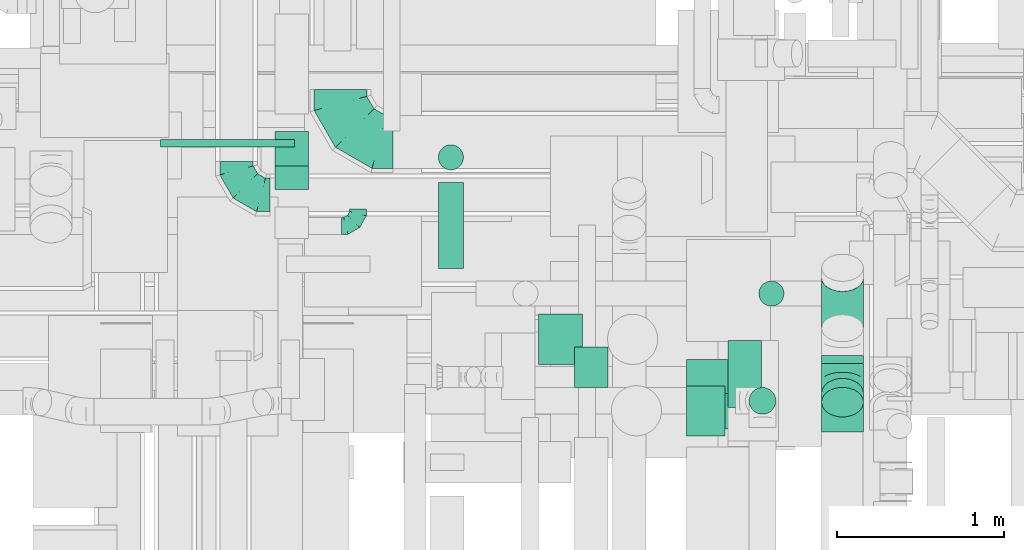
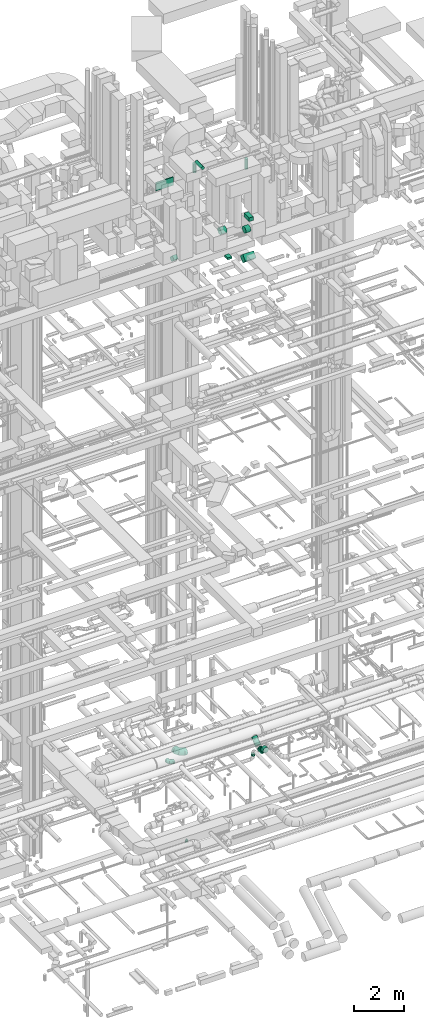
# One storey, part 185 of 337: 14 flow segments, 5 flow fittings.
"""IFC2X3 building model written with IfcOpenShell, lengths in millimetres."""

from ifc_helpers import new_model, entity, si_unit, converted_unit, derived_unit, direction, frame, frame_2d, origin, origin_2d_with_axis, place, context, subcontext, project, spatial, rectangle, circle, extrude, faceted_brep, source, transform, mapped, material, type_object, type_shapes, element, save


model = new_model("IFC2X3")

# Units and contexts
model_context = context("Model", 3, precision=0.01, world=origin(), true_north=direction((6.12303176911189e-17, 1.0)))
body_context = subcontext(model_context, "Body", "Model", "MODEL_VIEW")
ifc_project = project(units=[si_unit("LENGTHUNIT", "METRE", prefix="MILLI"), si_unit("AREAUNIT", "SQUARE_METRE"), si_unit("VOLUMEUNIT", "CUBIC_METRE"), converted_unit("PLANEANGLEUNIT", "DEGREE", entity("IfcRatioMeasure", 0.0174532925199433), si_unit("PLANEANGLEUNIT", "RADIAN"), dimensions=[0, 0, 0, 0, 0, 0, 0]), si_unit("MASSUNIT", "GRAM", prefix="KILO"), derived_unit("MASSDENSITYUNIT", [(si_unit("MASSUNIT", "GRAM", prefix="KILO"), 1), (si_unit("LENGTHUNIT", "METRE"), -3)]), derived_unit("MOMENTOFINERTIAUNIT", [(si_unit("LENGTHUNIT", "METRE"), 4)]), si_unit("TIMEUNIT", "SECOND"), si_unit("FREQUENCYUNIT", "HERTZ"), si_unit("THERMODYNAMICTEMPERATUREUNIT", "DEGREE_CELSIUS"), derived_unit("THERMALTRANSMITTANCEUNIT", [(si_unit("MASSUNIT", "GRAM", prefix="KILO"), 1), (si_unit("THERMODYNAMICTEMPERATUREUNIT", "KELVIN"), -1), (si_unit("TIMEUNIT", "SECOND"), -3)]), derived_unit("VOLUMETRICFLOWRATEUNIT", [(si_unit("LENGTHUNIT", "METRE"), 3), (si_unit("TIMEUNIT", "SECOND"), -1)]), derived_unit("MASSFLOWRATEUNIT", [(si_unit("MASSUNIT", "GRAM", prefix="KILO"), 1), (si_unit("TIMEUNIT", "SECOND"), -1)]), derived_unit("ROTATIONALFREQUENCYUNIT", [(si_unit("TIMEUNIT", "SECOND"), -1)]), si_unit("ELECTRICCURRENTUNIT", "AMPERE"), si_unit("ELECTRICVOLTAGEUNIT", "VOLT"), si_unit("POWERUNIT", "WATT"), si_unit("FORCEUNIT", "NEWTON", prefix="KILO"), si_unit("ILLUMINANCEUNIT", "LUX"), si_unit("LUMINOUSFLUXUNIT", "LUMEN"), si_unit("LUMINOUSINTENSITYUNIT", "CANDELA"), derived_unit("USERDEFINED", [(si_unit("MASSUNIT", "GRAM", prefix="KILO"), -1), (si_unit("LENGTHUNIT", "METRE"), -2), (si_unit("TIMEUNIT", "SECOND"), 3), (si_unit("LUMINOUSFLUXUNIT", "LUMEN"), 1)]), derived_unit("LINEARVELOCITYUNIT", [(si_unit("LENGTHUNIT", "METRE"), 1), (si_unit("TIMEUNIT", "SECOND"), -1)]), si_unit("PRESSUREUNIT", "PASCAL"), derived_unit("USERDEFINED", [(si_unit("LENGTHUNIT", "METRE"), -2), (si_unit("MASSUNIT", "GRAM", prefix="KILO"), 1), (si_unit("TIMEUNIT", "SECOND"), -2)]), derived_unit("LINEARFORCEUNIT", [(si_unit("MASSUNIT", "GRAM", prefix="KILO"), 1), (si_unit("LENGTHUNIT", "METRE"), 1), (si_unit("TIMEUNIT", "SECOND"), -2), (si_unit("LENGTHUNIT", "METRE"), -1)]), derived_unit("PLANARFORCEUNIT", [(si_unit("MASSUNIT", "GRAM", prefix="KILO"), 1), (si_unit("LENGTHUNIT", "METRE"), 1), (si_unit("TIMEUNIT", "SECOND"), -2), (si_unit("LENGTHUNIT", "METRE"), -2)])], contexts=[model_context])

# Site, building, storey
site_placement = place(None, origin())
site = spatial("IfcSite", under=ifc_project, at=site_placement, CompositionType="ELEMENT")
building_placement = place(site_placement, origin())
building = spatial("IfcBuilding", under=site, at=building_placement, CompositionType="ELEMENT")
storey_placement = place(building_placement, origin())
storey = spatial("IfcBuildingStorey", under=building, at=storey_placement, CompositionType="ELEMENT", Elevation=0.0)

# Flow segments
duct_segment_type_1 = type_object("IfcDuctSegmentType", PredefinedType="NOTDEFINED")
flow_segment_1_placement = place(storey_placement, frame((52445.02, 8280.79, 27500.0)))
element("IfcFlowSegment", 1, at=flow_segment_1_placement, inside=storey, type_object=duct_segment_type_1, context=body_context, shape_type="SweptSolid", body=[
    extrude(rectangle(XDim=240.0, YDim=199.999999999998, at=origin_2d_with_axis()), frame((100.0, 120.0, 0.0), z_axis=(0.0, 0.0, 1.0), x_axis=(0.0, 1.0, 0.0)), (0.0, 0.0, 1.0), 100.000000000003),
])
flow_segment_2_placement = place(storey_placement, frame((53363.63, 8160.0, 29120.0)))
element("IfcFlowSegment", 2, at=flow_segment_2_placement, inside=storey, type_object=duct_segment_type_1, context=body_context, shape_type="SweptSolid", body=[
    extrude(rectangle(XDim=200.000000000007, YDim=400.0, at=origin_2d_with_axis()), frame((100.0, 200.0, 0.0)), (0.0, 0.0, 1.0), 177.000000000224),
])
flow_segment_3_placement = place(storey_placement, frame((50656.62, 9462.61, 27202.51)))
element("IfcFlowSegment", 3, at=flow_segment_3_placement, inside=storey, type_object=duct_segment_type_1, context=body_context, shape_type="SweptSolid", body=[
    extrude(rectangle(XDim=200.0, YDim=200.000000000007, at=frame_2d((0.0, 0.0), x_axis=(0.0, 1.0))), frame((100.0, 274.26, 70.71), z_axis=(0.0, -0.707106781186512, 0.707106781186583), x_axis=(1.0, 0.0, 0.0)), (0.0, 0.0, 1.0), 287.867965643984),
])
flow_segment_4_placement = place(storey_placement, frame((53115.82, 8031.64, 27151.8)))
element("IfcFlowSegment", 4, at=flow_segment_4_placement, inside=storey, type_object=duct_segment_type_1, context=body_context, shape_type="SweptSolid", body=[
    extrude(rectangle(XDim=288.873016277954, YDim=300.000000000001, at=origin_2d_with_axis()), frame((0.0, 208.2, 208.2), z_axis=(1.0, 0.0, 0.0), x_axis=(0.0, -0.707106781186527, 0.707106781186568)), (0.0, 0.0, 1.0), 500.000000000008),
])
flow_segment_5_placement = place(storey_placement, frame((49973.61, 9717.0, 30855.0)))
element("IfcFlowSegment", 5, at=flow_segment_5_placement, inside=storey, type_object=duct_segment_type_1, context=body_context, shape_type="SweptSolid", body=[
    extrude(rectangle(XDim=44.5000208984928, YDim=800.0, at=origin_2d_with_axis()), frame((400.0, 22.25, 0.0), z_axis=(0.0, 0.0, 1.0), x_axis=(-1.43434809199216e-08, 1.0, 0.0)), (0.0, 0.0, 1.0), 399.999999999996),
])
duct_segment_type_2 = type_object("IfcDuctSegmentType", PredefinedType="NOTDEFINED")
flow_segment_6_placement = place(storey_placement, frame((52230.61, 8415.77, 28653.7)))
element("IfcFlowSegment", 6, at=flow_segment_6_placement, inside=storey, type_object=duct_segment_type_2, context=body_context, shape_type="SweptSolid", body=[
    extrude(circle(Radius=150.0, at=origin_2d_with_axis()), frame((0.0, 151.6, 151.6), z_axis=(1.0, 0.0, 0.0), x_axis=(0.0, 1.0, 0.0)), (0.0, 0.0, 1.0), 262.77069741607),
])
flow_segment_7_placement = place(storey_placement, frame((53115.87, 7989.08, 28675.9)))
element("IfcFlowSegment", 7, at=flow_segment_7_placement, inside=storey, type_object=duct_segment_type_2, context=body_context, shape_type="SweptSolid", body=[
    extrude(circle(Radius=150.0, at=origin_2d_with_axis()), frame((0.0, 151.6, 151.6), z_axis=(1.0, 0.0, 0.0), x_axis=(0.0, -1.0, 0.0)), (0.0, 0.0, 1.0), 227.761914020999),
])
flow_segment_8_placement = place(storey_placement, frame((51631.4, 8990.5, 31723.4)))
element("IfcFlowSegment", 8, at=flow_segment_8_placement, inside=storey, type_object=duct_segment_type_2, context=body_context, shape_type="SweptSolid", body=[
    extrude(circle(Radius=75.0, at=origin_2d_with_axis()), frame((76.6, 0.0, 76.6), z_axis=(0.0, 1.0, 0.0), x_axis=(1.0, 0.0, 0.0)), (0.0, 0.0, 1.0), 514.215146999739),
])
flow_segment_9_placement = place(storey_placement, frame((51631.4, 9578.12, 31208.0)))
element("IfcFlowSegment", 9, at=flow_segment_9_placement, inside=storey, type_object=duct_segment_type_2, context=body_context, shape_type="SweptSolid", body=[
    extrude(circle(Radius=75.0, at=origin_2d_with_axis()), frame((76.6, 76.6, 0.0), z_axis=(0.0, 0.0, 1.0), x_axis=(-1.0, 0.0, 0.0)), (0.0, 0.0, 1.0), 442.002731163149),
])
flow_segment_10_placement = place(storey_placement, frame((53545.76, 8763.9, 31208.0)))
element("IfcFlowSegment", 10, at=flow_segment_10_placement, inside=storey, type_object=duct_segment_type_2, context=body_context, shape_type="SweptSolid", body=[
    extrude(circle(Radius=75.0, at=origin_2d_with_axis()), frame((76.6, 76.6, 0.0)), (0.0, 0.0, 1.0), 497.002731163141),
])
flow_segment_11_placement = place(storey_placement, frame((53920.34, 8102.18, 3033.24)))
element("IfcFlowSegment", 11, at=flow_segment_11_placement, inside=storey, type_object=duct_segment_type_2, context=body_context, shape_type="SweptSolid", body=[
    extrude(circle(Radius=125.0, at=origin_2d_with_axis()), frame((126.6, 143.54, 89.98), z_axis=(0.0, -0.707106781186554, 0.707106781186541), x_axis=(1.0, 0.0, 0.0)), (0.0, 0.0, 1.0), 75.7359312880771),
])
flow_segment_12_placement = place(storey_placement, frame((53920.34, 8422.49, 2923.4)))
element("IfcFlowSegment", 12, at=flow_segment_12_placement, inside=storey, type_object=duct_segment_type_2, context=body_context, shape_type="SweptSolid", body=[
    extrude(circle(Radius=125.0, at=origin_2d_with_axis()), frame((126.6, 0.0, 126.6), z_axis=(0.0, 1.0, 0.0), x_axis=(-1.0, 0.0, 0.0)), (0.0, 0.0, 1.0), 49.5413949964432),
])
flow_segment_13_placement = place(storey_placement, frame((53920.34, 8551.48, 3012.9)))
element("IfcFlowSegment", 13, at=flow_segment_13_placement, inside=storey, type_object=duct_segment_type_2, context=body_context, shape_type="SweptSolid", body=[
    extrude(circle(Radius=125.0, at=origin_2d_with_axis()), frame((126.6, 82.64, 96.76), z_axis=(0.0, 0.7613381350106, 0.648355029423371), x_axis=(-1.0, 0.0, 0.0)), (0.0, 0.0, 1.0), 394.579843857995),
])
flow_segment_14_placement = place(storey_placement, frame((53487.31, 8118.43, 3060.0)))
element("IfcFlowSegment", 14, at=flow_segment_14_placement, inside=storey, type_object=duct_segment_type_2, context=body_context, shape_type="SweptSolid", body=[
    extrude(circle(Radius=80.0, at=origin_2d_with_axis()), frame((81.6, 81.6, 0.0), z_axis=(0.0, 0.0, 1.0), x_axis=(0.0, 1.0, 0.0)), (0.0, 0.0, 1.0), 80.0000000000663),
])

# Flow fittings
ifc_material = material()
duct_fitting_type_1 = type_object("IfcDuctFittingType", PredefinedType="NOTDEFINED", material=ifc_material)
shared_shape_1 = source(origin(), body_context, "Body", "Brep", [
    faceted_brep([(-100.0, 0.0, -50.0), (-100.0, -12.94, -48.3), (-100.0, -25.0, -43.3), (-100.0, -35.36, -35.36), (-100.0, -43.3, -25.0), (-100.0, -48.3, -12.94), (-100.0, -50.0, 0.0), (-100.0, -48.3, 12.94), (-100.0, -43.3, 25.0), (-100.0, -35.36, 35.36), (-100.0, -25.0, 43.3), (-100.0, -12.94, 48.3), (-100.0, 0.0, 50.0), (-100.0, 12.94, 48.3), (-100.0, 25.0, 43.3), (-100.0, 35.36, 35.36), (-100.0, 43.3, 25.0), (-100.0, 48.3, 12.94), (-100.0, 50.0, 0.0), (-100.0, 48.3, -12.94), (-100.0, 43.3, -25.0), (-100.0, 35.36, -35.36), (-100.0, 25.0, -43.3), (-100.0, 12.94, -48.3), (-76.67, 12.94, 48.3), (-79.9, 25.0, 43.3), (-73.21, 0.0, 50.0), (-82.68, 35.36, 35.36), (-86.15, 48.3, 12.94), (-86.6, 50.0, 0.0), (-84.81, 43.3, 25.0), (-84.81, 43.3, -25.0), (-82.68, 35.36, -35.36), (-86.15, 48.3, -12.94), (-76.67, 12.94, -48.3), (-73.21, 0.0, -50.0), (-79.9, 25.0, -43.3), (-69.74, -12.94, -48.3), (-66.51, -25.0, -43.3), (-63.73, -35.36, -35.36), (-61.6, -43.3, -25.0), (-60.26, -48.3, -12.94), (-59.81, -50.0, 0.0), (-60.26, -48.3, 12.94), (-61.6, -43.3, 25.0), (-63.73, -35.36, 35.36), (-66.51, -25.0, 43.3), (-69.74, -12.94, 48.3), (-36.27, 36.27, 48.3), (-45.1, 45.1, 43.3), (-26.79, 26.79, 50.0), (-52.68, 52.68, 35.36), (-58.49, 58.49, 25.0), (-62.15, 62.15, 12.94), (-63.4, 63.4, 0.0), (-62.15, 62.15, -12.94), (-58.49, 58.49, -25.0), (-52.68, 52.68, -35.36), (-36.27, 36.27, -48.3), (-26.79, 26.79, -50.0), (-45.1, 45.1, -43.3), (-17.32, 17.32, -48.3), (-8.49, 8.49, -43.3), (-0.91, 0.91, -35.36), (4.9, -4.9, -25.0), (8.56, -8.56, -12.94), (9.81, -9.81, 0.0), (8.56, -8.56, 12.94), (4.9, -4.9, 25.0), (-0.91, 0.91, 35.36), (-8.49, 8.49, 43.3), (-17.32, 17.32, 48.3), (-12.94, 76.67, 48.3), (-25.0, 79.9, 43.3), (0.0, 73.21, 50.0), (-35.36, 82.68, 35.36), (-43.3, 84.81, 25.0), (-48.3, 86.15, 12.94), (-50.0, 86.6, 0.0), (-48.3, 86.15, -12.94), (-43.3, 84.81, -25.0), (-35.36, 82.68, -35.36), (-12.94, 76.67, -48.3), (0.0, 73.21, -50.0), (-25.0, 79.9, -43.3), (12.94, 69.74, -48.3), (25.0, 66.51, -43.3), (35.36, 63.73, -35.36), (43.3, 61.6, -25.0), (48.3, 60.26, -12.94), (50.0, 59.81, 0.0), (48.3, 60.26, 12.94), (43.3, 61.6, 25.0), (35.36, 63.73, 35.36), (25.0, 66.51, 43.3), (12.94, 69.74, 48.3), (-12.94, 100.0, -48.3), (-25.0, 100.0, -43.3), (-35.36, 100.0, -35.36), (-43.3, 100.0, -25.0), (-48.3, 100.0, -12.94), (-50.0, 100.0, 0.0), (-48.3, 100.0, 12.94), (-43.3, 100.0, 25.0), (-35.36, 100.0, 35.36), (-25.0, 100.0, 43.3), (-12.94, 100.0, 48.3), (0.0, 100.0, 50.0), (12.94, 100.0, 48.3), (25.0, 100.0, 43.3), (35.36, 100.0, 35.36), (43.3, 100.0, 25.0), (48.3, 100.0, 12.94), (50.0, 100.0, 0.0), (48.3, 100.0, -12.94), (43.3, 100.0, -25.0), (35.36, 100.0, -35.36), (25.0, 100.0, -43.3), (12.94, 100.0, -48.3), (0.0, 100.0, -50.0)], [[[0, 1, 2, 3, 4, 5, 6, 7, 8, 9, 10, 11, 12, 13, 14, 15, 16, 17, 18, 19, 20, 21, 22, 23]], [[24, 25, 14, 13]], [[26, 24, 13, 12]], [[14, 25, 27, 15]], [[28, 29, 18, 17]], [[30, 28, 17, 16]], [[15, 27, 30, 16]], [[20, 31, 32, 21]], [[33, 31, 20, 19]], [[18, 29, 33, 19]], [[34, 35, 0, 23]], [[36, 34, 23, 22]], [[32, 36, 22, 21]], [[2, 1, 37, 38]], [[3, 2, 38, 39]], [[0, 35, 37, 1]], [[5, 4, 40, 41]], [[6, 5, 41, 42]], [[3, 39, 40, 4]], [[6, 42, 43, 7]], [[7, 43, 44, 8]], [[8, 44, 45, 9]], [[10, 46, 47, 11]], [[11, 47, 26, 12]], [[10, 9, 45, 46]], [[48, 49, 25, 24]], [[50, 48, 24, 26]], [[27, 25, 49, 51]], [[52, 53, 28, 30]], [[51, 52, 30, 27]], [[29, 28, 53, 54]], [[55, 56, 31, 33]], [[54, 55, 33, 29]], [[57, 32, 31, 56]], [[58, 59, 35, 34]], [[60, 58, 34, 36]], [[57, 60, 36, 32]], [[37, 35, 59, 61]], [[38, 37, 61, 62]], [[39, 38, 62, 63]], [[41, 40, 64, 65]], [[42, 41, 65, 66]], [[63, 64, 40, 39]], [[43, 42, 66, 67]], [[44, 43, 67, 68]], [[68, 69, 45, 44]], [[46, 45, 69, 70]], [[47, 46, 70, 71]], [[26, 47, 71, 50]], [[72, 73, 49, 48]], [[74, 72, 48, 50]], [[51, 49, 73, 75]], [[76, 77, 53, 52]], [[75, 76, 52, 51]], [[54, 53, 77, 78]], [[79, 80, 56, 55]], [[78, 79, 55, 54]], [[81, 57, 56, 80]], [[82, 83, 59, 58]], [[84, 82, 58, 60]], [[81, 84, 60, 57]], [[61, 59, 83, 85]], [[62, 61, 85, 86]], [[63, 62, 86, 87]], [[65, 64, 88, 89]], [[66, 65, 89, 90]], [[87, 88, 64, 63]], [[67, 66, 90, 91]], [[68, 67, 91, 92]], [[92, 93, 69, 68]], [[70, 69, 93, 94]], [[71, 70, 94, 95]], [[50, 71, 95, 74]], [[96, 97, 98, 99, 100, 101, 102, 103, 104, 105, 106, 107, 108, 109, 110, 111, 112, 113, 114, 115, 116, 117, 118, 119]], [[72, 74, 107, 106]], [[73, 72, 106, 105]], [[75, 73, 105, 104]], [[77, 76, 103, 102]], [[78, 77, 102, 101]], [[75, 104, 103, 76]], [[78, 101, 100, 79]], [[79, 100, 99, 80]], [[80, 99, 98, 81]], [[96, 119, 83, 82]], [[97, 96, 82, 84]], [[84, 81, 98, 97]], [[83, 119, 118, 85]], [[85, 118, 117, 86]], [[86, 117, 116, 87]], [[88, 115, 114, 89]], [[89, 114, 113, 90]], [[87, 116, 115, 88]], [[91, 90, 113, 112]], [[92, 91, 112, 111]], [[93, 92, 111, 110]], [[95, 94, 109, 108]], [[74, 95, 108, 107]], [[110, 109, 94, 93]]]),
])
type_shapes(duct_fitting_type_1, [shared_shape_1])
flow_fitting_1_placement = place(storey_placement, frame((51153.52, 9245.01, -900.0)))
element("IfcFlowFitting", 15, at=flow_fitting_1_placement, inside=storey, type_object=duct_fitting_type_1, material=ifc_material, context=body_context, shape_type="MappedRepresentation", body=[
    mapped(shared_shape_1, transform((0.0, 0.0, 0.0), scale=1.0)),
])
duct_fitting_type_2 = type_object("IfcDuctFittingType", PredefinedType="NOTDEFINED", material=ifc_material)
shared_shape_2 = source(origin(), body_context, "Body", "Brep", [
    faceted_brep([(-200.0, 0.0, -100.0), (-200.0, -25.88, -96.59), (-200.0, -50.0, -86.6), (-200.0, -70.71, -70.71), (-200.0, -86.6, -50.0), (-200.0, -96.59, -25.88), (-200.0, -100.0, 0.0), (-200.0, -96.59, 25.88), (-200.0, -86.6, 50.0), (-200.0, -70.71, 70.71), (-200.0, -50.0, 86.6), (-200.0, -25.88, 96.59), (-200.0, 0.0, 100.0), (-200.0, 25.88, 96.59), (-200.0, 50.0, 86.6), (-200.0, 70.71, 70.71), (-200.0, 86.6, 50.0), (-200.0, 96.59, 25.88), (-200.0, 100.0, 0.0), (-200.0, 96.59, -25.88), (-200.0, 86.6, -50.0), (-200.0, 70.71, -70.71), (-200.0, 50.0, -86.6), (-200.0, 25.88, -96.59), (-153.35, 25.88, 96.59), (-159.81, 50.0, 86.6), (-146.41, 0.0, 100.0), (-165.36, 70.71, 70.71), (-172.29, 96.59, 25.88), (-173.21, 100.0, 0.0), (-169.62, 86.6, 50.0), (-169.62, 86.6, -50.0), (-165.36, 70.71, -70.71), (-172.29, 96.59, -25.88), (-153.35, 25.88, -96.59), (-146.41, 0.0, -100.0), (-159.81, 50.0, -86.6), (-139.48, -25.88, -96.59), (-133.01, -50.0, -86.6), (-127.46, -70.71, -70.71), (-123.21, -86.6, -50.0), (-120.53, -96.59, -25.88), (-119.62, -100.0, 0.0), (-120.53, -96.59, 25.88), (-123.21, -86.6, 50.0), (-127.46, -70.71, 70.71), (-133.01, -50.0, 86.6), (-139.48, -25.88, 96.59), (-72.54, 72.54, 96.59), (-90.19, 90.19, 86.6), (-53.59, 53.59, 100.0), (-105.35, 105.35, 70.71), (-116.99, 116.99, 50.0), (-124.3, 124.3, 25.88), (-126.79, 126.79, 0.0), (-124.3, 124.3, -25.88), (-116.99, 116.99, -50.0), (-105.35, 105.35, -70.71), (-72.54, 72.54, -96.59), (-53.59, 53.59, -100.0), (-90.19, 90.19, -86.6), (-34.64, 34.64, -96.59), (-16.99, 16.99, -86.6), (-1.83, 1.83, -70.71), (9.81, -9.81, -50.0), (17.12, -17.12, -25.88), (19.62, -19.62, 0.0), (17.12, -17.12, 25.88), (9.81, -9.81, 50.0), (-1.83, 1.83, 70.71), (-16.99, 16.99, 86.6), (-34.64, 34.64, 96.59), (-25.88, 153.35, 96.59), (-50.0, 159.81, 86.6), (0.0, 146.41, 100.0), (-70.71, 165.36, 70.71), (-86.6, 169.62, 50.0), (-96.59, 172.29, 25.88), (-100.0, 173.21, 0.0), (-96.59, 172.29, -25.88), (-86.6, 169.62, -50.0), (-70.71, 165.36, -70.71), (-25.88, 153.35, -96.59), (0.0, 146.41, -100.0), (-50.0, 159.81, -86.6), (25.88, 139.48, -96.59), (50.0, 133.01, -86.6), (70.71, 127.46, -70.71), (86.6, 123.21, -50.0), (96.59, 120.53, -25.88), (100.0, 119.62, 0.0), (96.59, 120.53, 25.88), (86.6, 123.21, 50.0), (70.71, 127.46, 70.71), (50.0, 133.01, 86.6), (25.88, 139.48, 96.59), (-25.88, 200.0, -96.59), (-50.0, 200.0, -86.6), (-70.71, 200.0, -70.71), (-86.6, 200.0, -50.0), (-96.59, 200.0, -25.88), (-100.0, 200.0, 0.0), (-96.59, 200.0, 25.88), (-86.6, 200.0, 50.0), (-70.71, 200.0, 70.71), (-50.0, 200.0, 86.6), (-25.88, 200.0, 96.59), (0.0, 200.0, 100.0), (25.88, 200.0, 96.59), (50.0, 200.0, 86.6), (70.71, 200.0, 70.71), (86.6, 200.0, 50.0), (96.59, 200.0, 25.88), (100.0, 200.0, 0.0), (96.59, 200.0, -25.88), (86.6, 200.0, -50.0), (70.71, 200.0, -70.71), (50.0, 200.0, -86.6), (25.88, 200.0, -96.59), (0.0, 200.0, -100.0)], [[[0, 1, 2, 3, 4, 5, 6, 7, 8, 9, 10, 11, 12, 13, 14, 15, 16, 17, 18, 19, 20, 21, 22, 23]], [[24, 25, 14, 13]], [[26, 24, 13, 12]], [[14, 25, 27, 15]], [[28, 29, 18, 17]], [[30, 28, 17, 16]], [[15, 27, 30, 16]], [[20, 31, 32, 21]], [[33, 31, 20, 19]], [[18, 29, 33, 19]], [[34, 35, 0, 23]], [[36, 34, 23, 22]], [[32, 36, 22, 21]], [[1, 0, 35, 37]], [[2, 1, 37, 38]], [[38, 39, 3, 2]], [[5, 4, 40, 41]], [[6, 5, 41, 42]], [[39, 40, 4, 3]], [[6, 42, 43, 7]], [[7, 43, 44, 8]], [[8, 44, 45, 9]], [[9, 45, 46, 10]], [[10, 46, 47, 11]], [[26, 12, 11, 47]], [[48, 49, 25, 24]], [[50, 48, 24, 26]], [[27, 25, 49, 51]], [[52, 53, 28, 30]], [[51, 52, 30, 27]], [[29, 28, 53, 54]], [[55, 56, 31, 33]], [[54, 55, 33, 29]], [[32, 31, 56, 57]], [[58, 59, 35, 34]], [[60, 58, 34, 36]], [[57, 60, 36, 32]], [[37, 35, 59, 61]], [[38, 37, 61, 62]], [[39, 38, 62, 63]], [[41, 40, 64, 65]], [[42, 41, 65, 66]], [[63, 64, 40, 39]], [[43, 42, 66, 67]], [[44, 43, 67, 68]], [[68, 69, 45, 44]], [[46, 45, 69, 70]], [[47, 46, 70, 71]], [[26, 47, 71, 50]], [[72, 73, 49, 48]], [[74, 72, 48, 50]], [[51, 49, 73, 75]], [[76, 77, 53, 52]], [[75, 76, 52, 51]], [[54, 53, 77, 78]], [[79, 80, 56, 55]], [[78, 79, 55, 54]], [[57, 56, 80, 81]], [[82, 83, 59, 58]], [[84, 82, 58, 60]], [[81, 84, 60, 57]], [[61, 59, 83, 85]], [[62, 61, 85, 86]], [[63, 62, 86, 87]], [[65, 64, 88, 89]], [[66, 65, 89, 90]], [[87, 88, 64, 63]], [[67, 66, 90, 91]], [[68, 67, 91, 92]], [[92, 93, 69, 68]], [[70, 69, 93, 94]], [[71, 70, 94, 95]], [[50, 71, 95, 74]], [[96, 97, 98, 99, 100, 101, 102, 103, 104, 105, 106, 107, 108, 109, 110, 111, 112, 113, 114, 115, 116, 117, 118, 119]], [[72, 74, 107, 106]], [[73, 72, 106, 105]], [[75, 73, 105, 104]], [[102, 101, 78, 77]], [[103, 102, 77, 76]], [[75, 104, 103, 76]], [[78, 101, 100, 79]], [[79, 100, 99, 80]], [[80, 99, 98, 81]], [[84, 97, 96, 82]], [[82, 96, 119, 83]], [[84, 81, 98, 97]], [[118, 117, 86, 85]], [[119, 118, 85, 83]], [[116, 87, 86, 117]], [[88, 115, 114, 89]], [[89, 114, 113, 90]], [[115, 88, 87, 116]], [[91, 90, 113, 112]], [[92, 91, 112, 111]], [[111, 110, 93, 92]], [[95, 94, 109, 108]], [[74, 95, 108, 107]], [[110, 109, 94, 93]]]),
])
type_shapes(duct_fitting_type_2, [shared_shape_2])
flow_fitting_2_placement = place(storey_placement, frame((50427.16, 9429.95, 3050.0), z_axis=(0.0, 0.0, 1.0), x_axis=(0.0, -1.0, 0.0)))
element("IfcFlowFitting", 16, at=flow_fitting_2_placement, inside=storey, type_object=duct_fitting_type_2, material=ifc_material, context=body_context, shape_type="MappedRepresentation", body=[
    mapped(shared_shape_2, transform((0.0, 0.0, 0.0), scale=1.0)),
])
duct_fitting_type_3 = type_object("IfcDuctFittingType", PredefinedType="NOTDEFINED", material=ifc_material)
shared_shape_3 = source(origin(), body_context, "Body", "Brep", [
    faceted_brep([(-103.55, 0.0, -125.0), (-103.55, -32.35, -120.74), (-103.55, -62.5, -108.25), (-103.55, -88.39, -88.39), (-103.55, -108.25, -62.5), (-103.55, -120.74, -32.35), (-103.55, -125.0, 0.0), (-103.55, -120.74, 32.35), (-103.55, -108.25, 62.5), (-103.55, -88.39, 88.39), (-103.55, -62.5, 108.25), (-103.55, -32.35, 120.74), (-103.55, 0.0, 125.0), (-103.55, 32.35, 120.74), (-103.55, 62.5, 108.25), (-103.55, 88.39, 88.39), (-103.55, 108.25, 62.5), (-103.55, 120.74, 32.35), (-103.55, 125.0, 0.0), (-103.55, 120.74, -32.35), (-103.55, 108.25, -62.5), (-103.55, 88.39, -88.39), (-103.55, 62.5, -108.25), (-103.55, 32.35, -120.74), (-13.4, 32.35, 120.74), (-25.89, 62.5, 108.25), (0.0, 0.0, 125.0), (-36.61, 88.39, 88.39), (-44.84, 108.25, 62.5), (-50.01, 120.74, 32.35), (-51.78, 125.0, 0.0), (-50.01, 120.74, -32.35), (-44.84, 108.25, -62.5), (-36.61, 88.39, -88.39), (-13.4, 32.35, -120.74), (0.0, 0.0, -125.0), (-25.89, 62.5, -108.25), (13.4, -32.35, -120.74), (25.89, -62.5, -108.25), (36.61, -88.39, -88.39), (44.84, -108.25, -62.5), (50.01, -120.74, -32.35), (51.78, -125.0, 0.0), (50.01, -120.74, 32.35), (44.84, -108.25, 62.5), (36.61, -88.39, 88.39), (25.89, -62.5, 108.25), (13.4, -32.35, 120.74), (73.22, 73.22, 125.0), (50.35, 96.1, 120.74), (29.03, 117.42, 108.25), (10.72, 135.72, 88.39), (-3.32, 149.77, 62.5), (-12.15, 158.6, 32.35), (-15.17, 161.61, 0.0), (-12.15, 158.6, -32.35), (-3.32, 149.77, -62.5), (10.72, 135.72, -88.39), (29.03, 117.42, -108.25), (50.35, 96.1, -120.74), (73.22, 73.22, -125.0), (96.1, 50.35, -120.74), (117.42, 29.03, -108.25), (135.72, 10.72, -88.39), (149.77, -3.32, -62.5), (158.6, -12.15, -32.35), (161.61, -15.17, 0.0), (158.6, -12.15, 32.35), (149.77, -3.32, 62.5), (135.72, 10.72, 88.39), (117.42, 29.03, 108.25), (96.1, 50.35, 120.74)], [[[0, 1, 2, 3, 4, 5, 6, 7, 8, 9, 10, 11, 12, 13, 14, 15, 16, 17, 18, 19, 20, 21, 22, 23]], [[24, 25, 14, 13]], [[26, 24, 13, 12]], [[14, 25, 27, 15]], [[28, 29, 17, 16]], [[28, 16, 15, 27]], [[30, 18, 17, 29]], [[31, 32, 20, 19]], [[30, 31, 19, 18]], [[32, 33, 21, 20]], [[34, 35, 0, 23]], [[36, 34, 23, 22]], [[33, 36, 22, 21]], [[1, 0, 35, 37]], [[2, 1, 37, 38]], [[38, 39, 3, 2]], [[5, 4, 40, 41]], [[6, 5, 41, 42]], [[39, 40, 4, 3]], [[6, 42, 43, 7]], [[7, 43, 44, 8]], [[8, 44, 45, 9]], [[9, 45, 46, 10]], [[10, 46, 47, 11]], [[26, 12, 11, 47]], [[24, 26, 48, 49]], [[25, 24, 49, 50]], [[27, 25, 50, 51]], [[29, 28, 52, 53]], [[30, 29, 53, 54]], [[51, 52, 28, 27]], [[30, 54, 55, 31]], [[31, 55, 56, 32]], [[57, 33, 32, 56]], [[36, 58, 59, 34]], [[34, 59, 60, 35]], [[58, 36, 33, 57]], [[35, 60, 61, 37]], [[37, 61, 62, 38]], [[63, 39, 38, 62]], [[40, 64, 65, 41]], [[41, 65, 66, 42]], [[64, 40, 39, 63]], [[43, 42, 66, 67]], [[44, 43, 67, 68]], [[68, 69, 45, 44]], [[47, 46, 70, 71]], [[26, 47, 71, 48]], [[69, 70, 46, 45]], [[59, 58, 57, 56, 55, 54, 53, 52, 51, 50, 49, 48, 71, 70, 69, 68, 67, 66, 65, 64, 63, 62, 61, 60]]]),
])
type_shapes(duct_fitting_type_3, [shared_shape_3])
for number, where, z_axis, x_axis in (
    (17, (54046.94, 8118.94, 3250.0), (-1.0, 0.0, 0.0), (0.0, 1.0, 0.0)),
    (18, (54046.94, 8318.94, 3050.0), (1.0, 0.0, 0.0), (0.0, 0.707106781186476, -0.707106781186619)),
):
    element("IfcFlowFitting", number, at=place(storey_placement, frame(where, z_axis=z_axis, x_axis=x_axis)), inside=storey, type_object=duct_fitting_type_3, material=ifc_material, context=body_context, shape_type="MappedRepresentation", body=[
        mapped(shared_shape_3, transform((0.0, 0.0, 0.0), scale=1.0)),
    ])
duct_fitting_type_4 = type_object("IfcDuctFittingType", PredefinedType="NOTDEFINED", material=ifc_material)
shared_shape_4 = source(origin(), body_context, "Body", "Brep", [
    faceted_brep([(-315.0, 0.0, -157.5), (-315.0, -40.76, -152.13), (-315.0, -78.75, -136.4), (-315.0, -111.37, -111.37), (-315.0, -136.4, -78.75), (-315.0, -152.13, -40.76), (-315.0, -157.5, 0.0), (-315.0, -152.13, 40.76), (-315.0, -136.4, 78.75), (-315.0, -111.37, 111.37), (-315.0, -78.75, 136.4), (-315.0, -40.76, 152.13), (-315.0, 0.0, 157.5), (-315.0, 40.76, 152.13), (-315.0, 78.75, 136.4), (-315.0, 111.37, 111.37), (-315.0, 136.4, 78.75), (-315.0, 152.13, 40.76), (-315.0, 157.5, 0.0), (-315.0, 152.13, -40.76), (-315.0, 136.4, -78.75), (-315.0, 111.37, -111.37), (-315.0, 78.75, -136.4), (-315.0, 40.76, -152.13), (-241.52, 40.76, 152.13), (-251.7, 78.75, 136.4), (-230.6, 0.0, 157.5), (-260.44, 111.37, 111.37), (-271.36, 152.13, 40.76), (-272.8, 157.5, 0.0), (-267.14, 136.4, 78.75), (-267.14, 136.4, -78.75), (-260.44, 111.37, -111.37), (-271.36, 152.13, -40.76), (-241.52, 40.76, -152.13), (-230.6, 0.0, -157.5), (-251.7, 78.75, -136.4), (-219.67, -40.76, -152.13), (-209.5, -78.75, -136.4), (-200.75, -111.37, -111.37), (-194.05, -136.4, -78.75), (-189.83, -152.13, -40.76), (-188.39, -157.5, 0.0), (-189.83, -152.13, 40.76), (-194.05, -136.4, 78.75), (-200.75, -111.37, 111.37), (-209.5, -78.75, 136.4), (-219.67, -40.76, 152.13), (-114.25, 114.25, 152.13), (-142.05, 142.05, 136.4), (-84.4, 84.4, 157.5), (-165.93, 165.93, 111.37), (-184.25, 184.25, 78.75), (-195.77, 195.77, 40.76), (-199.7, 199.7, 0.0), (-195.77, 195.77, -40.76), (-184.25, 184.25, -78.75), (-165.93, 165.93, -111.37), (-114.25, 114.25, -152.13), (-84.4, 84.4, -157.5), (-142.05, 142.05, -136.4), (-54.56, 54.56, -152.13), (-26.75, 26.75, -136.4), (-2.88, 2.88, -111.37), (15.45, -15.45, -78.75), (26.97, -26.97, -40.76), (30.89, -30.89, 0.0), (26.97, -26.97, 40.76), (15.45, -15.45, 78.75), (-2.88, 2.88, 111.37), (-26.75, 26.75, 136.4), (-54.56, 54.56, 152.13), (-40.76, 241.52, 152.13), (-78.75, 251.7, 136.4), (0.0, 230.6, 157.5), (-111.37, 260.44, 111.37), (-136.4, 267.14, 78.75), (-152.13, 271.36, 40.76), (-157.5, 272.8, 0.0), (-152.13, 271.36, -40.76), (-136.4, 267.14, -78.75), (-111.37, 260.44, -111.37), (-40.76, 241.52, -152.13), (0.0, 230.6, -157.5), (-78.75, 251.7, -136.4), (40.76, 219.67, -152.13), (78.75, 209.5, -136.4), (111.37, 200.75, -111.37), (136.4, 194.05, -78.75), (152.13, 189.83, -40.76), (157.5, 188.39, 0.0), (152.13, 189.83, 40.76), (136.4, 194.05, 78.75), (111.37, 200.75, 111.37), (78.75, 209.5, 136.4), (40.76, 219.67, 152.13), (-40.76, 315.0, -152.13), (-78.75, 315.0, -136.4), (-111.37, 315.0, -111.37), (-136.4, 315.0, -78.75), (-152.13, 315.0, -40.76), (-157.5, 315.0, 0.0), (-152.13, 315.0, 40.76), (-136.4, 315.0, 78.75), (-111.37, 315.0, 111.37), (-78.75, 315.0, 136.4), (-40.76, 315.0, 152.13), (0.0, 315.0, 157.5), (40.76, 315.0, 152.13), (78.75, 315.0, 136.4), (111.37, 315.0, 111.37), (136.4, 315.0, 78.75), (152.13, 315.0, 40.76), (157.5, 315.0, 0.0), (152.13, 315.0, -40.76), (136.4, 315.0, -78.75), (111.37, 315.0, -111.37), (78.75, 315.0, -136.4), (40.76, 315.0, -152.13), (0.0, 315.0, -157.5)], [[[0, 1, 2, 3, 4, 5, 6, 7, 8, 9, 10, 11, 12, 13, 14, 15, 16, 17, 18, 19, 20, 21, 22, 23]], [[24, 25, 14, 13]], [[26, 24, 13, 12]], [[14, 25, 27, 15]], [[28, 29, 18, 17]], [[30, 28, 17, 16]], [[15, 27, 30, 16]], [[20, 31, 32, 21]], [[33, 31, 20, 19]], [[18, 29, 33, 19]], [[34, 35, 0, 23]], [[36, 34, 23, 22]], [[32, 36, 22, 21]], [[1, 0, 35, 37]], [[2, 1, 37, 38]], [[38, 39, 3, 2]], [[5, 4, 40, 41]], [[6, 5, 41, 42]], [[39, 40, 4, 3]], [[6, 42, 43, 7]], [[7, 43, 44, 8]], [[8, 44, 45, 9]], [[9, 45, 46, 10]], [[10, 46, 47, 11]], [[26, 12, 11, 47]], [[48, 49, 25, 24]], [[50, 48, 24, 26]], [[27, 25, 49, 51]], [[52, 53, 28, 30]], [[51, 52, 30, 27]], [[29, 28, 53, 54]], [[55, 56, 31, 33]], [[54, 55, 33, 29]], [[32, 31, 56, 57]], [[58, 59, 35, 34]], [[60, 58, 34, 36]], [[57, 60, 36, 32]], [[37, 35, 59, 61]], [[38, 37, 61, 62]], [[39, 38, 62, 63]], [[41, 40, 64, 65]], [[42, 41, 65, 66]], [[63, 64, 40, 39]], [[43, 42, 66, 67]], [[44, 43, 67, 68]], [[68, 69, 45, 44]], [[46, 45, 69, 70]], [[47, 46, 70, 71]], [[26, 47, 71, 50]], [[72, 73, 49, 48]], [[74, 72, 48, 50]], [[51, 49, 73, 75]], [[76, 77, 53, 52]], [[75, 76, 52, 51]], [[54, 53, 77, 78]], [[79, 80, 56, 55]], [[78, 79, 55, 54]], [[57, 56, 80, 81]], [[82, 83, 59, 58]], [[84, 82, 58, 60]], [[81, 84, 60, 57]], [[61, 59, 83, 85]], [[62, 61, 85, 86]], [[63, 62, 86, 87]], [[65, 64, 88, 89]], [[66, 65, 89, 90]], [[87, 88, 64, 63]], [[67, 66, 90, 91]], [[68, 67, 91, 92]], [[92, 93, 69, 68]], [[70, 69, 93, 94]], [[71, 70, 94, 95]], [[50, 71, 95, 74]], [[96, 97, 98, 99, 100, 101, 102, 103, 104, 105, 106, 107, 108, 109, 110, 111, 112, 113, 114, 115, 116, 117, 118, 119]], [[106, 105, 73, 72]], [[107, 106, 72, 74]], [[75, 73, 105, 104]], [[77, 76, 103, 102]], [[78, 77, 102, 101]], [[104, 103, 76, 75]], [[78, 101, 100, 79]], [[79, 100, 99, 80]], [[98, 81, 80, 99]], [[84, 97, 96, 82]], [[82, 96, 119, 83]], [[97, 84, 81, 98]], [[83, 119, 118, 85]], [[85, 118, 117, 86]], [[116, 87, 86, 117]], [[88, 115, 114, 89]], [[89, 114, 113, 90]], [[115, 88, 87, 116]], [[91, 90, 113, 112]], [[92, 91, 112, 111]], [[111, 110, 93, 92]], [[95, 94, 109, 108]], [[74, 95, 108, 107]], [[110, 109, 94, 93]]]),
])
type_shapes(duct_fitting_type_4, [shared_shape_4])
flow_fitting_3_placement = place(storey_placement, frame((51048.26, 9745.88, 3099.97), z_axis=(-8.92429004956488e-06, -1.06852234971895e-06, 1.0), x_axis=(0.0, -1.0, -1.0685223497615e-06)))
element("IfcFlowFitting", 19, at=flow_fitting_3_placement, inside=storey, type_object=duct_fitting_type_4, material=ifc_material, context=body_context, shape_type="MappedRepresentation", body=[
    mapped(shared_shape_4, transform((0.0, 0.0, 0.0), scale=1.0)),
])

save(model, "model.ifc")
